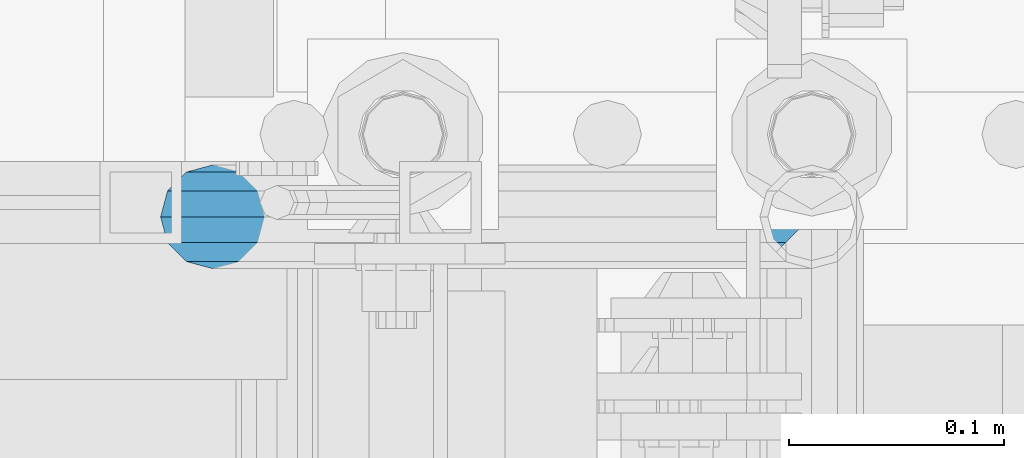
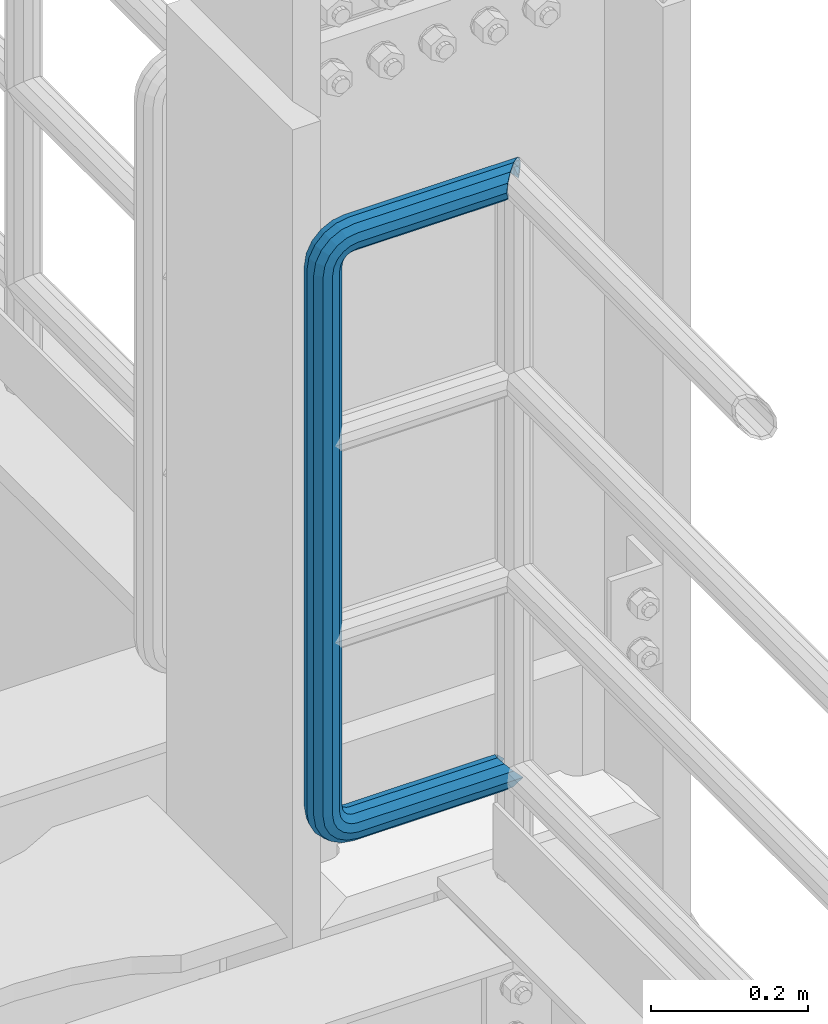
# One storey, part 993 of 1876: 1 beam, 1 element without a shape of its own.
"""IFC2X3 building model written with IfcOpenShell, lengths in millimetres."""

from ifc_helpers import new_model, si_unit, frame, origin_with_axes, place, context, subcontext, project, spatial, faceted_brep, material, type_object, element, aggregate, save


model = new_model("IFC2X3")

# Units and contexts
model_context = context("Model", 3, precision=1e-05, world=origin_with_axes())
body_context = subcontext(model_context, "Body", "Model", "MODEL_VIEW")
ifc_project = project(units=[si_unit("LENGTHUNIT", "METRE", prefix="MILLI"), si_unit("AREAUNIT", "SQUARE_METRE"), si_unit("VOLUMEUNIT", "CUBIC_METRE"), si_unit("MASSUNIT", "GRAM", prefix="KILO"), si_unit("TIMEUNIT", "SECOND"), si_unit("PLANEANGLEUNIT", "RADIAN"), si_unit("SOLIDANGLEUNIT", "STERADIAN"), si_unit("THERMODYNAMICTEMPERATUREUNIT", "DEGREE_CELSIUS"), si_unit("LUMINOUSINTENSITYUNIT", "LUMEN")], contexts=[model_context])

# Site, building, storey
site_placement = place(None, origin_with_axes())
site = spatial("IfcSite", under=ifc_project, at=site_placement, CompositionType="ELEMENT")
building_placement = place(site_placement, origin_with_axes())
building = spatial("IfcBuilding", under=site, at=building_placement, Name="Undefined", CompositionType="ELEMENT")
storey_placement = place(building_placement, origin_with_axes())
storey = spatial("IfcBuildingStorey", under=building, at=storey_placement, Name="Undefined", CompositionType="ELEMENT", Elevation=0.0)

# Assembly, beam
assembly_placement = place(storey_placement, origin_with_axes())
assembly = element("IfcElementAssembly", 1, at=assembly_placement, inside=storey, Name="RAIL", AssemblyPlace="NOTDEFINED", PredefinedType="RIGID_FRAME")
ifc_material = material()
beam_type = type_object("IfcBeamType", Name="PIPE1-1/2SCH40", PredefinedType="NOTDEFINED")
beam_placement = place(assembly_placement, frame((7620.0, -4788.2175, 14385.925), z_axis=(0.0, 0.0, 1.0), x_axis=(-1.0, 0.0, 0.0)))
beam = element("IfcBeam", 2, at=beam_placement, type_object=beam_type, material=ifc_material, Name="RAIL", ObjectType="PIPE1-1/2SCH40", context=body_context, shape_type="Brep", body=[
    faceted_brep([(16.4810964966631, 16.4810964966564, -11.4500249345219), (16.481099754581, 16.4810997545774, -16.4810932387409), (20.8971929933249, 12.0650000000005, -20.8971929933177), (20.8971929933249, 12.0650000000005, -15.8661214311796), (0.0, -24.1299999999992, 0.0), (12.0650000000014, -20.8971929933186, 0.0), (12.0650000000064, -20.8971929933177, -12.0649999999987), (-12.0650000000096, -20.8971929933177, -12.0649999999987), (-12.0649999999986, -20.8971929933186, 0.0), (-16.481093238739, -16.4810932387427, -16.4810997545756), (-16.4810964966554, -16.4810964966618, -11.4500249345183), (-15.2545715621367, -17.7076214311801, -10.2235000000001), (-12.5151929933171, -20.4470000000001, 0.0), (12.5151929933249, -20.4470000000001, 0.0), (20.8971929933249, -12.0650000000005, -15.8661214311796), (20.8971929933249, -12.0650000000005, -20.8971929933177), (15.2545715621445, -17.7076214311801, -10.2235000000001), (24.1300000000063, 0.0, -20.4470000000001), (24.1300000000063, 0.0, -24.130000000001), (21.3906214311868, -10.2235000000001, -17.7076214311819), (21.3906214311868, 10.2235000000001, -17.7076214311819), (1.20714750983051e-12, 24.1299999999974, -914.399963378906), (12.0650000000014, 20.8971929933159, -926.464963378905), (12.0650000000014, 20.8971929933177, -902.334963378908), (12.0650000000014, -20.8971929933195, -902.334963378908), (12.0650000000014, -20.8971929933195, -926.464963378905), (1.52133659548828e-12, -24.130000000001, -914.399963378906), (20.8971929933199, -12.0650000000023, -893.502770385589), (20.8971929933199, -12.0650000000005, -898.533841947723), (15.2545715621378, -17.7076214311819, -904.176463378906), (12.5151929933181, -20.4470000000019, -914.399963378906), (15.2545715621376, -17.7076214311819, -924.623463378906), (20.8971929933199, -12.0650000000005, -930.26608481009), (20.8971929933199, -12.0650000000023, -935.297156372224), (24.1300000000014, -1.81898940354586e-12, -934.846963378906), (24.1300000000014, -1.81898940354586e-12, -938.529963378907), (21.3906214311813, -10.2235000000019, -932.107584810088), (21.3906214311823, 10.2234999999982, -932.107584810088), (20.8971929933199, 12.0650000000005, -930.266084810086), (20.8971929933199, 12.0649999999987, -935.297156372224), (15.2545715621413, 17.7076214311783, -924.623463378906), (12.5151929933216, 20.4469999999983, -914.399963378906), (15.2545715621411, 17.7076214311783, -904.176463378906), (20.8971929933199, 12.0650000000005, -898.533841947727), (20.8971929933199, 12.0649999999987, -893.502770385589), (21.3906214311822, 10.2234999999982, -896.692341947724), (24.1300000000014, 0.0, -893.952963378906), (24.1300000000014, 0.0, -890.269963378905), (21.3906214311814, -10.2235000000019, -896.692341947724), (241.299995422363, -20.8971929933177, 12.0649999999987), (241.299995422363, -24.1299999999992, 0.0), (253.073542436527, -24.1299999999992, -1.86474665447167), (256.801832473661, -20.8971929933177, 9.60975021462946), (241.299995422363, -12.0650000000005, 20.8971929933177), (259.531130206197, -12.0650000000005, 18.0096649141014), (241.299995422363, 0.0, 24.130000000001), (260.530122510796, 0.0, 21.084247083727), (241.299995422363, 12.0650000000005, 20.8971929933177), (259.531130206197, 12.0650000000005, 18.0096649141014), (241.299995422363, 20.8971929933177, 12.0649999999987), (256.801832473661, 20.8971929933177, 9.60975021462946), (241.299995422363, 24.1299999999992, 0.0), (253.073542436527, 24.1299999999992, -1.86474665447167), (241.299995422363, 20.8971929933177, -12.0649999999987), (249.345252399393, 20.8971929933177, -13.3392435235728), (241.299995422363, 12.0650000000005, -20.8971929933177), (246.615954666858, 12.0650000000005, -21.7391582230448), (241.299995422363, 0.0, -24.130000000001), (245.616962362259, 0.0, -24.8137403926739), (241.299995422363, -12.0650000000005, -20.8971929933177), (246.615954666858, -12.0650000000005, -21.7391582230448), (241.299995422363, -20.8971929933177, -12.0649999999987), (249.345252399393, -20.8971929933177, -13.3392435235728), (267.334993896485, 20.8971929933177, -38.0999984741211), (279.399993896485, 24.1299999999992, -38.0999984741211), (279.399993896484, 24.1299999999992, -876.299964904785), (267.334993896484, 20.8971929933177, -876.299964904785), (291.464993896486, 20.8971929933177, -38.0999984741211), (291.464993896484, 20.8971929933177, -876.299964904785), (300.297186889804, 12.0650000000005, -38.0999984741211), (300.297186889803, 12.0650000000005, -876.299964904785), (303.529993896486, 0.0, -38.0999984741211), (303.529993896484, 0.0, -876.299964904785), (300.297186889804, -12.0650000000005, -38.0999984741211), (300.297186889803, -12.0650000000005, -876.299964904785), (291.464993896486, -20.8971929933177, -38.0999984741211), (291.464993896484, -20.8971929933177, -876.299964904785), (279.399993896484, -24.1299999999992, -38.0999984741211), (279.399993896484, -24.1299999999992, -876.299964904785), (267.334993896485, -20.8971929933177, -38.0999984741211), (267.334993896484, -20.8971929933177, -876.299964904785), (258.502800903167, -12.0650000000005, -38.0999984741211), (258.502800903166, -12.0650000000005, -876.299964904785), (255.269993896485, 0.0, -38.0999984741211), (255.269993896484, 0.0, -876.299964904785), (258.502800903167, 12.0650000000005, -38.0999984741211), (258.502800903166, 12.0650000000005, -876.299964904785), (257.660835673438, 12.0650000000005, -881.615924149282), (254.586253503809, 0.0, -880.616931844681), (257.660835673438, -12.0650000000005, -881.615924149282), (266.06075037291, -20.8971929933177, -884.345221881817), (277.535247242011, -24.130000000001, -888.073511918952), (289.009744111112, -20.8971929933195, -891.801801956084), (297.409658810584, -12.0650000000005, -894.531099688622), (300.484240980214, 0.0, -895.53009199322), (297.409658810584, 12.0650000000005, -894.531099688622), (289.009744111112, 20.8971929933177, -891.801801956084), (277.535247242011, 24.1299999999992, -888.073511918952), (266.06075037291, 20.8971929933177, -884.345221881817), (241.299995422364, -1.81898940354586e-12, -938.529963378911), (241.299995422364, -12.0650000000005, -935.297156372228), (241.299995422364, -20.8971929933195, -926.464963378909), (241.299995422363, -24.130000000001, -914.399963378906), (241.299995422363, -20.8971929933195, -902.334963378908), (241.299995422363, -12.0650000000005, -893.502770385589), (241.299995422363, 0.0, -890.269963378909), (241.299995422364, 20.8971929933177, -926.464963378909), (241.299995422364, 12.0649999999987, -935.297156372228), (241.299995422364, 24.1299999999992, -914.39996337891), (241.299995422363, 20.8971929933177, -902.334963378908), (241.299995422363, 12.0649999999987, -893.502770385589), (260.530122510801, 0.0, -935.484210462637), (259.531130206202, 12.0649999999987, -932.409628293008), (259.531130206201, -12.0650000000005, -932.409628293008), (256.801832473666, -20.8971929933195, -924.009713593536), (253.07354243653, -24.130000000001, -912.535216724435), (249.345252399395, -20.8971929933195, -901.060719855333), (246.615954666859, -12.0650000000005, -892.660805155861), (245.61696236226, 0.0, -889.586222986232), (246.615954666859, 12.0649999999987, -892.660805155861), (249.345252399395, 20.8971929933177, -901.060719855333), (253.07354243653, 24.1299999999992, -912.535216724435), (256.801832473666, 20.8971929933177, -924.009713593536), (275.977674493594, 12.0649999999987, -924.029695422345), (270.786241706733, 20.8971929933177, -916.884301193139), (277.877870775644, 0.0, -926.645091230272), (275.977674493608, -12.0650000000005, -924.029695422334), (270.786241706733, -20.8971929933195, -916.884301193139), (263.694612637823, -24.130000000001, -907.123511156005), (256.602983568912, -20.8971929933195, -897.362721118872), (251.411550782037, -12.0650000000005, -890.21732688968), (249.511354500001, 0.0, -887.601931081743), (251.411550782037, 12.0650000000005, -890.21732688968), (256.602983568912, 20.8971929933177, -897.362721118872), (263.694612637823, 24.1299999999992, -907.123511156005), (281.884331710718, 20.8971929933177, -905.786211189152), (272.123541673585, 24.1299999999992, -898.694582120243), (289.029725939912, 12.0650000000005, -910.977643976028), (291.645121747852, 0.0, -912.877840258065), (289.029725939912, -12.0650000000005, -910.977643976028), (281.884331710718, -20.8971929933195, -905.786211189152), (272.123541673585, -24.130000000001, -898.694582120243), (262.362751636451, -20.8971929933195, -891.602953051333), (255.217357407258, -12.0650000000005, -886.411520264461), (252.601961599318, 0.0, -884.511323982424), (255.217357407258, 12.0650000000005, -886.411520264461), (262.362751636451, 20.8971929933177, -891.602953051333), (266.060750372911, 20.8971929933177, -30.0547414970897), (257.660835673439, 12.0650000000005, -32.7840392296275), (277.535247242011, 24.1299999999992, -26.3264514599541), (289.009744111112, 20.8971929933177, -22.5981614228222), (297.409658810584, 12.0650000000005, -19.8688636902843), (300.484240980213, 0.0, -18.8698713856866), (297.409658810584, -12.0650000000005, -19.8688636902843), (289.009744111112, -20.8971929933177, -22.5981614228222), (277.535247242011, -24.1299999999992, -26.3264514599541), (266.060750372911, -20.8971929933177, -30.0547414970897), (257.660835673439, -12.0650000000005, -32.7840392296275), (254.58625350381, 0.0, -33.7830315342253), (255.217357407257, 12.0650000000005, -27.9884431144455), (252.601961599318, 0.0, -29.8886393964822), (262.362751636451, 20.8971929933177, -22.7970103275729), (272.123541673583, 24.1299999999992, -15.7053812586601), (281.884331710716, 20.8971929933177, -8.61375218975081), (289.029725939909, 12.0650000000005, -3.42231940287456), (291.645121747848, 0.0, -1.52212312084157), (289.029725939909, -12.0650000000005, -3.42231940287456), (281.884331710716, -20.8971929933177, -8.61375218975081), (272.123541673583, -24.1299999999992, -15.7053812586601), (262.362751636451, -20.8971929933177, -22.7970103275729), (255.217357407257, -12.0650000000005, -27.9884431144455), (249.511354500002, 0.0, -26.7980322971671), (251.411550782037, -12.0650000000005, -24.1826364892258), (251.411550782037, 12.0650000000005, -24.1826364892258), (256.602983568912, 20.8971929933177, -17.037242260034), (263.694612637822, 24.1299999999992, -7.27645222290084), (270.786241706732, 20.8971929933177, 2.48433781423228), (275.977674493607, 12.0650000000005, 9.62973204342416), (277.877870775642, 0.0, 12.2451278513654), (275.977674493607, -12.0650000000005, 9.62973204342416), (270.786241706732, -20.8971929933177, 2.48433781423228), (263.694612637822, -24.1299999999992, -7.27645222290084), (256.602983568912, -20.8971929933177, -17.037242260034), (20.8971929933232, 20.8971929933177, -12.0649999999987), (24.1300000000047, 24.1299999999992, 0.0), (20.8971929933232, 20.8971929933177, 12.0649999999987), (12.0650000000041, 12.0650000000005, 20.8971929933177), (-1.45519152283669e-11, 0.0, 24.130000000001), (-12.0649999999951, -12.0650000000005, 20.8971929933177), (-20.8971929933141, -20.8971929933177, 12.0649999999987), (-24.1299999999956, -24.1299999999992, 0.0), (-20.8971929933141, -20.8971929933177, -12.0649999999987), (-17.7076214311755, -17.7076214311801, -10.2235000000001), (-20.4469999999956, -20.4470000000001, 0.0), (-17.7076214311755, -17.7076214311801, 10.2235000000001), (241.299995422363, -17.7076214311801, 10.2235000000001), (241.299995422363, -20.4470000000001, 0.0), (241.299995422363, -17.7076214311801, -10.2235000000001), (241.299995422363, -10.2235000000001, -17.7076214311819), (241.299995422363, 0.0, -20.4470000000001), (241.299995422363, 0.0, 20.4470000000001), (241.299995422363, -10.2235000000001, 17.7076214311819), (-10.2234999999955, -10.2235000000001, 17.7076214311819), (-1.45519152283669e-11, 0.0, 20.4470000000001), (241.299995422363, 10.2235000000001, 17.7076214311819), (10.2235000000046, 10.2235000000001, 17.7076214311819), (241.299995422363, 17.7076214311801, 10.2235000000001), (17.7076214311846, 17.7076214311801, 10.2235000000001), (241.299995422363, 20.4470000000001, 0.0), (20.4470000000047, 20.4470000000001, 0.0), (241.299995422363, 17.7076214311801, -10.2235000000001), (17.7076214311846, 17.7076214311801, -10.2235000000001), (241.299995422363, 10.2235000000001, -17.7076214311819), (258.545498388721, -10.2235000000001, 14.9762020957387), (256.23277767852, -17.7076214311801, 7.85837963987069), (253.073542436527, -20.4470000000001, -1.86474665447167), (249.914307194535, -17.7076214311801, -11.5878729488177), (247.601586484334, -10.2235000000001, -18.7056954046857), (246.755071952542, 0.0, -21.31099924316), (247.601586484334, 10.2235000000001, -18.7056954046857), (249.914307194535, 17.7076214311801, -11.5878729488177), (253.073542436527, 20.4470000000001, -1.86474665447167), (256.23277767852, 17.7076214311801, 7.85837963987069), (258.545498388721, 10.2235000000001, 14.9762020957387), (259.392012920513, 0.0, 17.5815059342131), (275.713057691449, 0.0, 9.26551826108334), (274.10289136825, -10.2235000000001, 7.04931444488102), (274.10289136825, 10.2235000000001, 7.04931444488102), (269.703835164635, 17.7076214311801, 0.994533019089431), (263.694612637822, 20.4470000000001, -7.27645222290084), (257.685390111009, 17.7076214311801, -15.5474374648911), (253.286333907394, 10.2235000000001, -21.6022188906827), (251.676167584195, 0.0, -23.818422706885), (253.286333907394, -10.2235000000001, -21.6022188906827), (257.685390111009, -17.7076214311801, -15.5474374648911), (263.694612637822, -20.4470000000001, -7.27645222290084), (269.703835164635, -17.7076214311801, 0.994533019089431), (286.449308341364, -10.2235000000001, -5.29710252823133), (280.394526915574, -17.7076214311801, -9.69615873184739), (288.665512157566, 0.0, -3.68693620503473), (286.449308341364, 10.2235000000001, -5.29710252823133), (280.394526915574, 17.7076214311801, -9.69615873184739), (272.123541673583, 20.4470000000001, -15.7053812586601), (263.852556431592, 17.7076214311801, -21.7146037854764), (257.797775005802, 10.2235000000001, -26.1136599890888), (255.581571189601, 0.0, -27.723826312289), (257.797775005802, -10.2235000000001, -26.1136599890888), (263.852556431592, -17.7076214311801, -21.7146037854764), (272.123541673583, -20.4470000000001, -15.7053812586601), (287.258373536355, -17.7076214311801, -23.1672162179639), (277.535247242011, -20.4470000000001, -26.3264514599541), (294.376195992223, -10.2235000000001, -20.8544955077632), (296.981499830698, 0.0, -20.00798097597), (294.376195992223, 10.2235000000001, -20.8544955077632), (287.258373536355, 17.7076214311801, -23.1672162179639), (277.535247242011, 20.4470000000001, -26.3264514599541), (267.812120947668, 17.7076214311801, -29.485686701948), (260.6942984918, 10.2235000000001, -31.7984074121487), (258.088994653325, 0.0, -32.6449219439419), (260.6942984918, -10.2235000000001, -31.7984074121487), (267.812120947668, -17.7076214311801, -29.485686701948), (279.399993896484, -20.4470000000001, -38.0999984741211), (269.176493896485, -17.7076214311801, -38.0999984741211), (289.623493896486, -17.7076214311801, -38.0999984741211), (297.107615327666, -10.2235000000001, -38.0999984741211), (299.846993896486, 0.0, -38.0999984741211), (297.107615327666, 10.2235000000001, -38.0999984741211), (289.623493896486, 17.7076214311801, -38.0999984741211), (279.399993896485, 20.4470000000001, -38.0999984741211), (269.176493896485, 17.7076214311801, -38.0999984741211), (261.692372465305, 10.2235000000001, -38.0999984741211), (258.952993896485, 0.0, -38.0999984741211), (261.692372465305, -10.2235000000001, -38.0999984741211), (269.176493896484, -17.7076214311801, -876.299964904785), (261.692372465304, -10.2235000000001, -876.299964904785), (258.952993896484, 0.0, -876.299964904785), (261.692372465304, 10.2235000000001, -876.299964904785), (269.176493896484, 17.7076214311801, -876.299964904785), (279.399993896484, 20.4470000000001, -876.299964904785), (289.623493896484, 17.7076214311801, -876.299964904785), (297.107615327665, 10.2235000000001, -876.299964904785), (299.846993896484, 0.0, -876.299964904785), (297.107615327665, -10.2235000000001, -876.299964904785), (289.623493896484, -17.7076214311801, -876.299964904785), (279.399993896484, -20.4470000000001, -876.299964904785), (277.535247242011, -20.4470000000001, -888.073511918952), (267.812120947667, -17.7076214311801, -884.914276676958), (260.694298491799, -10.2235000000001, -882.601555966758), (258.088994653324, 0.0, -881.755041434964), (260.694298491799, 10.2235000000001, -882.601555966758), (267.812120947668, 17.7076214311801, -884.914276676958), (277.535247242011, 20.4470000000001, -888.073511918952), (287.258373536355, 17.7076214311801, -891.232747160942), (294.376195992223, 10.2235000000001, -893.545467871143), (296.981499830699, 0.0, -894.391982402936), (294.376195992223, -10.2235000000001, -893.545467871143), (287.258373536355, -17.7076214311801, -891.232747160942), (280.394526915577, -17.7076214311801, -904.703804647055), (272.123541673585, -20.4470000000001, -898.694582120243), (286.449308341367, -10.2235000000001, -909.102860850671), (288.665512157569, 0.0, -910.713027173868), (286.449308341367, 10.2235000000001, -909.102860850671), (280.394526915577, 17.7076214311801, -904.703804647055), (272.123541673585, 20.4470000000001, -898.694582120243), (263.852556431593, 17.7076214311801, -892.68535959343), (257.797775005802, 10.2235000000001, -888.286303389817), (255.581571189601, 0.0, -886.676137066617), (257.797775005802, -10.2235000000001, -888.286303389817), (263.852556431593, -17.7076214311801, -892.68535959343), (263.694612637823, -20.4470000000001, -907.123511156005), (257.685390111009, -17.7076214311801, -898.852525914015), (269.703835164636, -17.7076214311801, -915.394496397999), (274.102891368238, -10.2235000000001, -921.449277823798), (275.71305769145, 0.0, -923.66548163999), (274.102891368251, 10.2235000000001, -921.449277823787), (269.703835164636, 17.7076214311801, -915.394496397999), (263.694612637823, 20.4470000000001, -907.123511156005), (257.685390111009, 17.7076214311801, -898.852525914015), (253.286333907394, 10.2235000000001, -892.797744488227), (251.676167584195, 0.0, -890.581540672025), (253.286333907394, -10.2235000000001, -892.797744488227), (249.914307194537, -17.7076214311801, -902.812090430092), (247.601586484335, -10.2235000000001, -895.694267974224), (253.07354243653, -20.4470000000001, -912.535216724435), (256.232777678524, -17.7076214311819, -922.258343018777), (258.545498388725, -10.2235000000001, -929.376165474645), (259.392012920517, 0.0, -931.981469313119), (258.545498388725, 10.2235000000001, -929.376165474645), (256.232777678524, 17.7076214311801, -922.258343018777), (253.07354243653, 20.4470000000001, -912.535216724435), (249.914307194537, 17.7076214311801, -902.812090430092), (247.601586484335, 10.2235000000001, -895.694267974224), (246.755071952543, 0.0, -893.088964135746), (241.299995422363, -10.2235000000001, -896.692341947728), (241.299995422363, 0.0, -893.95296337891), (241.299995422363, -17.7076214311819, -904.17646337891), (241.299995422363, -20.4470000000001, -914.399963378906), (241.299995422364, -17.7076214311819, -924.62346337891), (241.299995422364, -10.2235000000001, -932.107584810088), (241.299995422364, -1.81898940354586e-12, -934.84696337891), (241.299995422364, 10.2234999999982, -932.107584810088), (241.299995422364, 17.7076214311801, -924.62346337891), (241.299995422364, 20.4470000000001, -914.39996337891), (241.299995422363, 17.7076214311801, -904.17646337891), (241.299995422363, 10.2235000000001, -896.692341947728)], [[[0, 1, 2, 3]], [[4, 5, 6]], [[7, 8, 4]], [[9, 10, 11, 12, 8, 7]], [[13, 5, 4, 8, 12]], [[14, 15, 6, 5, 13, 16]], [[17, 18, 15, 14, 19]], [[20, 3, 2, 18, 17]], [[21, 22, 23]], [[24, 25, 26]], [[27, 28, 29, 30, 31, 32, 33, 25, 24]], [[34, 35, 33, 32, 36]], [[37, 38, 39, 35, 34]], [[23, 22, 39, 38, 40, 41, 42, 43, 44]], [[44, 43, 45, 46, 47]], [[47, 46, 48, 28, 27]], [[49, 50, 51, 52]], [[53, 49, 52, 54]], [[55, 53, 54, 56]], [[57, 55, 56, 58]], [[59, 57, 58, 60]], [[61, 59, 60, 62]], [[63, 61, 62, 64]], [[65, 63, 64, 66]], [[67, 65, 66, 68]], [[69, 67, 68, 70]], [[71, 69, 70, 72]], [[73, 74, 75, 76]], [[74, 77, 78, 75]], [[77, 79, 80, 78]], [[79, 81, 82, 80]], [[81, 83, 84, 82]], [[83, 85, 86, 84]], [[85, 87, 88, 86]], [[87, 89, 90, 88]], [[89, 91, 92, 90]], [[91, 93, 94, 92]], [[93, 95, 96, 94]], [[94, 96, 97, 98]], [[92, 94, 98, 99]], [[90, 92, 99, 100]], [[88, 90, 100, 101]], [[86, 88, 101, 102]], [[84, 86, 102, 103]], [[82, 84, 103, 104]], [[80, 82, 104, 105]], [[78, 80, 105, 106]], [[75, 78, 106, 107]], [[76, 75, 107, 108]], [[109, 110, 33, 35]], [[110, 111, 25, 33]], [[111, 112, 26, 25]], [[112, 113, 24, 26]], [[113, 114, 27, 24]], [[114, 115, 47, 27]], [[116, 117, 39, 22]], [[118, 116, 22, 21]], [[119, 118, 21, 23]], [[120, 119, 23, 44]], [[115, 120, 44, 47]], [[117, 109, 35, 39]], [[121, 109, 117, 122]], [[123, 110, 109, 121]], [[124, 111, 110, 123]], [[125, 112, 111, 124]], [[126, 113, 112, 125]], [[127, 114, 113, 126]], [[128, 115, 114, 127]], [[129, 120, 115, 128]], [[130, 119, 120, 129]], [[131, 118, 119, 130]], [[132, 116, 118, 131]], [[122, 117, 116, 132]], [[133, 122, 132, 134]], [[135, 121, 122, 133]], [[136, 123, 121, 135]], [[137, 124, 123, 136]], [[138, 125, 124, 137]], [[139, 126, 125, 138]], [[140, 127, 126, 139]], [[141, 128, 127, 140]], [[142, 129, 128, 141]], [[143, 130, 129, 142]], [[144, 131, 130, 143]], [[134, 132, 131, 144]], [[145, 134, 144, 146]], [[147, 133, 134, 145]], [[148, 135, 133, 147]], [[149, 136, 135, 148]], [[150, 137, 136, 149]], [[151, 138, 137, 150]], [[152, 139, 138, 151]], [[153, 140, 139, 152]], [[154, 141, 140, 153]], [[155, 142, 141, 154]], [[156, 143, 142, 155]], [[146, 144, 143, 156]], [[107, 146, 156, 108]], [[106, 145, 146, 107]], [[105, 147, 145, 106]], [[104, 148, 147, 105]], [[103, 149, 148, 104]], [[102, 150, 149, 103]], [[101, 151, 150, 102]], [[100, 152, 151, 101]], [[99, 153, 152, 100]], [[98, 154, 153, 99]], [[97, 155, 154, 98]], [[108, 156, 155, 97]], [[96, 76, 108, 97]], [[95, 73, 76, 96]], [[157, 73, 95, 158]], [[159, 74, 73, 157]], [[160, 77, 74, 159]], [[161, 79, 77, 160]], [[162, 81, 79, 161]], [[163, 83, 81, 162]], [[164, 85, 83, 163]], [[165, 87, 85, 164]], [[166, 89, 87, 165]], [[167, 91, 89, 166]], [[168, 93, 91, 167]], [[158, 95, 93, 168]], [[169, 158, 168, 170]], [[171, 157, 158, 169]], [[172, 159, 157, 171]], [[173, 160, 159, 172]], [[174, 161, 160, 173]], [[175, 162, 161, 174]], [[176, 163, 162, 175]], [[177, 164, 163, 176]], [[178, 165, 164, 177]], [[179, 166, 165, 178]], [[180, 167, 166, 179]], [[170, 168, 167, 180]], [[181, 170, 180, 182]], [[183, 169, 170, 181]], [[184, 171, 169, 183]], [[185, 172, 171, 184]], [[186, 173, 172, 185]], [[187, 174, 173, 186]], [[188, 175, 174, 187]], [[189, 176, 175, 188]], [[190, 177, 176, 189]], [[191, 178, 177, 190]], [[192, 179, 178, 191]], [[182, 180, 179, 192]], [[70, 182, 192, 72]], [[68, 181, 182, 70]], [[66, 183, 181, 68]], [[64, 184, 183, 66]], [[62, 185, 184, 64]], [[60, 186, 185, 62]], [[58, 187, 186, 60]], [[56, 188, 187, 58]], [[54, 189, 188, 56]], [[52, 190, 189, 54]], [[51, 191, 190, 52]], [[72, 192, 191, 51]], [[50, 71, 72, 51]], [[71, 50, 4, 6]], [[69, 71, 6, 15]], [[67, 69, 15, 18]], [[65, 67, 18, 2]], [[193, 63, 65, 2, 1]], [[61, 63, 193, 194]], [[59, 61, 194, 195]], [[57, 59, 195, 196]], [[55, 57, 196, 197]], [[53, 55, 197, 198]], [[49, 53, 198, 199]], [[4, 50, 49, 199, 200]], [[200, 201, 7, 4]], [[201, 9, 7]], [[202, 11, 10]], [[202, 203, 12, 11]], [[203, 204, 205, 206, 13, 12]], [[206, 207, 16, 13]], [[16, 207, 208, 19, 14]], [[208, 209, 17, 19]], [[210, 211, 212, 213]], [[214, 210, 213, 215]], [[216, 214, 215, 217]], [[218, 216, 217, 219]], [[220, 218, 219, 221]], [[222, 220, 221, 0, 3, 20]], [[209, 222, 20, 17]], [[221, 219, 217, 215, 213, 212, 204, 203, 202, 10, 9, 201, 200, 199, 198, 197, 196, 195, 194, 193, 1, 0]], [[211, 205, 204, 212]], [[205, 211, 223, 224]], [[206, 205, 224, 225]], [[207, 206, 225, 226]], [[208, 207, 226, 227]], [[209, 208, 227, 228]], [[222, 209, 228, 229]], [[220, 222, 229, 230]], [[218, 220, 230, 231]], [[216, 218, 231, 232]], [[214, 216, 232, 233]], [[210, 214, 233, 234]], [[211, 210, 234, 223]], [[234, 235, 236, 223]], [[233, 237, 235, 234]], [[232, 238, 237, 233]], [[231, 239, 238, 232]], [[230, 240, 239, 231]], [[229, 241, 240, 230]], [[228, 242, 241, 229]], [[227, 243, 242, 228]], [[226, 244, 243, 227]], [[225, 245, 244, 226]], [[224, 246, 245, 225]], [[223, 236, 246, 224]], [[236, 247, 248, 246]], [[235, 249, 247, 236]], [[237, 250, 249, 235]], [[238, 251, 250, 237]], [[239, 252, 251, 238]], [[240, 253, 252, 239]], [[241, 254, 253, 240]], [[242, 255, 254, 241]], [[243, 256, 255, 242]], [[244, 257, 256, 243]], [[245, 258, 257, 244]], [[246, 248, 258, 245]], [[248, 259, 260, 258]], [[247, 261, 259, 248]], [[249, 262, 261, 247]], [[250, 263, 262, 249]], [[251, 264, 263, 250]], [[252, 265, 264, 251]], [[253, 266, 265, 252]], [[254, 267, 266, 253]], [[255, 268, 267, 254]], [[256, 269, 268, 255]], [[257, 270, 269, 256]], [[258, 260, 270, 257]], [[260, 271, 272, 270]], [[259, 273, 271, 260]], [[261, 274, 273, 259]], [[262, 275, 274, 261]], [[263, 276, 275, 262]], [[264, 277, 276, 263]], [[265, 278, 277, 264]], [[266, 279, 278, 265]], [[267, 280, 279, 266]], [[268, 281, 280, 267]], [[269, 282, 281, 268]], [[270, 272, 282, 269]], [[282, 272, 283, 284]], [[281, 282, 284, 285]], [[280, 281, 285, 286]], [[279, 280, 286, 287]], [[278, 279, 287, 288]], [[277, 278, 288, 289]], [[276, 277, 289, 290]], [[275, 276, 290, 291]], [[274, 275, 291, 292]], [[273, 274, 292, 293]], [[271, 273, 293, 294]], [[272, 271, 294, 283]], [[283, 294, 295, 296]], [[284, 283, 296, 297]], [[285, 284, 297, 298]], [[286, 285, 298, 299]], [[287, 286, 299, 300]], [[288, 287, 300, 301]], [[289, 288, 301, 302]], [[290, 289, 302, 303]], [[291, 290, 303, 304]], [[292, 291, 304, 305]], [[293, 292, 305, 306]], [[294, 293, 306, 295]], [[306, 307, 308, 295]], [[305, 309, 307, 306]], [[304, 310, 309, 305]], [[303, 311, 310, 304]], [[302, 312, 311, 303]], [[301, 313, 312, 302]], [[300, 314, 313, 301]], [[299, 315, 314, 300]], [[298, 316, 315, 299]], [[297, 317, 316, 298]], [[296, 318, 317, 297]], [[295, 308, 318, 296]], [[308, 319, 320, 318]], [[307, 321, 319, 308]], [[309, 322, 321, 307]], [[310, 323, 322, 309]], [[311, 324, 323, 310]], [[312, 325, 324, 311]], [[313, 326, 325, 312]], [[314, 327, 326, 313]], [[315, 328, 327, 314]], [[316, 329, 328, 315]], [[317, 330, 329, 316]], [[318, 320, 330, 317]], [[320, 331, 332, 330]], [[319, 333, 331, 320]], [[321, 334, 333, 319]], [[322, 335, 334, 321]], [[323, 336, 335, 322]], [[324, 337, 336, 323]], [[325, 338, 337, 324]], [[326, 339, 338, 325]], [[327, 340, 339, 326]], [[328, 341, 340, 327]], [[329, 342, 341, 328]], [[330, 332, 342, 329]], [[332, 343, 344, 342]], [[331, 345, 343, 332]], [[333, 346, 345, 331]], [[334, 347, 346, 333]], [[335, 348, 347, 334]], [[336, 349, 348, 335]], [[337, 350, 349, 336]], [[338, 351, 350, 337]], [[339, 352, 351, 338]], [[340, 353, 352, 339]], [[341, 354, 353, 340]], [[342, 344, 354, 341]], [[354, 344, 46, 45]], [[42, 353, 354, 45, 43]], [[352, 353, 42, 41]], [[351, 352, 41, 40]], [[350, 351, 40, 38, 37]], [[349, 350, 37, 34]], [[348, 349, 34, 36]], [[31, 347, 348, 36, 32]], [[346, 347, 31, 30]], [[345, 346, 30, 29]], [[343, 345, 29, 28, 48]], [[344, 343, 48, 46]]]),
])
aggregate(assembly, [beam])

save(model, "model.ifc")
